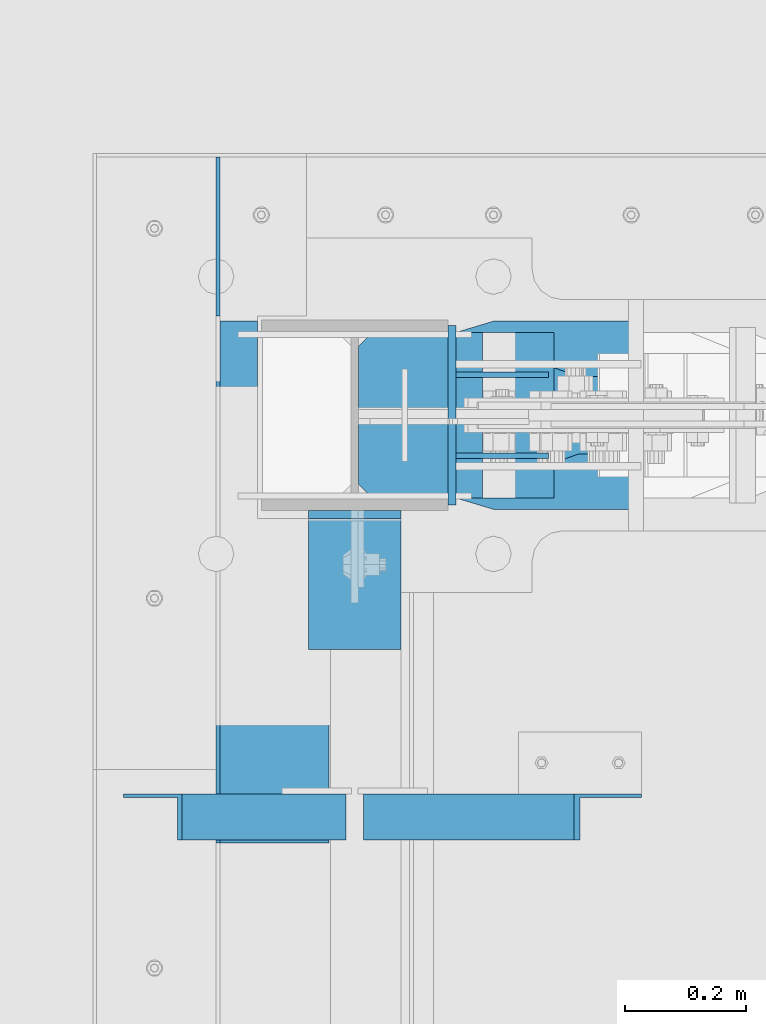
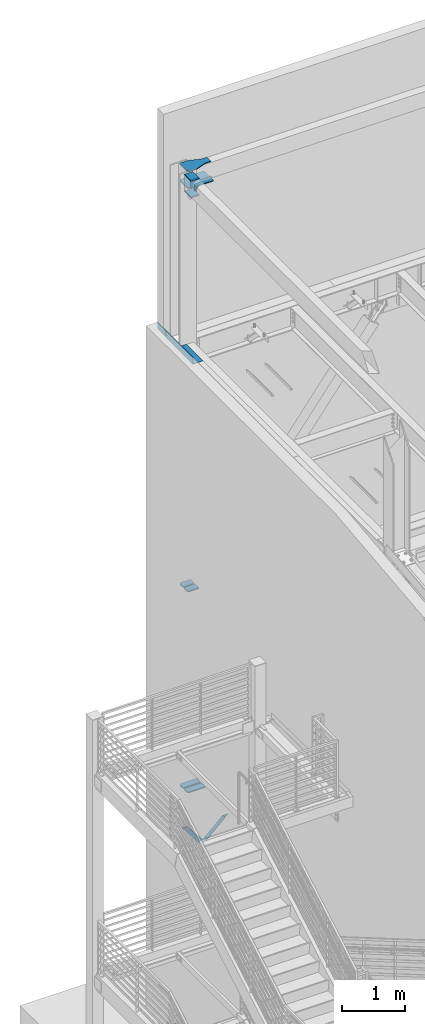
# One storey, part 881 of 1179: 13 beams, 2 members, 8 elements without a shape of their own.
"""IFC2X3 building model written with IfcOpenShell, lengths in millimetres."""

from ifc_helpers import new_model, si_unit, frame, origin_with_axes, place, context, subcontext, project, spatial, faceted_brep, material, type_object, element, aggregate, save


model = new_model("IFC2X3")

# Units and contexts
model_context = context("Model", 3, precision=1e-05, world=origin_with_axes())
body_context = subcontext(model_context, "Body", "Model", "MODEL_VIEW")
ifc_project = project(units=[si_unit("LENGTHUNIT", "METRE", prefix="MILLI"), si_unit("AREAUNIT", "SQUARE_METRE"), si_unit("VOLUMEUNIT", "CUBIC_METRE"), si_unit("MASSUNIT", "GRAM", prefix="KILO"), si_unit("TIMEUNIT", "SECOND"), si_unit("PLANEANGLEUNIT", "RADIAN"), si_unit("SOLIDANGLEUNIT", "STERADIAN"), si_unit("THERMODYNAMICTEMPERATUREUNIT", "DEGREE_CELSIUS"), si_unit("LUMINOUSINTENSITYUNIT", "LUMEN")], contexts=[model_context])

# Site, building, storey
site_placement = place(None, origin_with_axes())
site = spatial("IfcSite", under=ifc_project, at=site_placement, CompositionType="ELEMENT")
building_placement = place(site_placement, origin_with_axes())
building = spatial("IfcBuilding", under=site, at=building_placement, Name="Undefined", CompositionType="ELEMENT")
storey_placement = place(building_placement, origin_with_axes())
storey = spatial("IfcBuildingStorey", under=building, at=storey_placement, Name="Undefined", CompositionType="ELEMENT", Elevation=0.0)

# Assembly, member
assembly_1_placement = place(storey_placement, origin_with_axes())
assembly_1 = element("IfcElementAssembly", 1, at=assembly_1_placement, inside=storey, Name="ANGLE", AssemblyPlace="NOTDEFINED", PredefinedType="RIGID_FRAME")
ifc_material_1 = material(Name="STEEL/A36")
member_type = type_object("IfcMemberType", Name="L3X3X1/4", PredefinedType="NOTDEFINED")
member_1_placement = place(assembly_1_placement, frame((472.414639168561, 40536.8125, 3736.19330123132), z_axis=(0.0, -1.0, 0.0), x_axis=(0.729484494811633, 0.0, 0.683997347823379)))
member_1 = element("IfcMember", 2, at=member_1_placement, type_object=member_type, material=ifc_material_1, Name="ANGLE", ObjectType="L3X3X1/4", context=body_context, shape_type="Brep", body=[
    faceted_brep([(0.0, 38.0999999999985, -38.0999999999999), (0.0, 38.0999999999985, 38.0999999999999), (475.752341075195, 38.0999999999181, 38.1000000000004), (475.752341075195, 38.0999999999181, -38.1000000000004), (0.0, 31.75, 38.1000000000004), (482.524628360803, 31.7499999999177, 38.1000000000004), (0.0, 31.75, -31.75), (482.524628360803, 31.7499999999177, -31.75), (0.0, -38.0999999999985, -31.75), (557.019788502486, -38.1000000000854, -31.75), (0.0, -38.0999999999985, -38.0999999999999), (557.019788502486, -38.1000000000854, -38.1000000000004)], [[[0, 1, 2, 3]], [[1, 4, 5, 2]], [[4, 6, 7, 5]], [[6, 8, 9, 7]], [[8, 10, 11, 9]], [[10, 0, 3, 11]], [[5, 7, 9, 11, 3, 2]], [[10, 8, 6, 4, 1, 0]]]),
])
aggregate(assembly_1, [member_1])

assembly_2_placement = place(storey_placement, origin_with_axes())
assembly_2 = element("IfcElementAssembly", 3, at=assembly_2_placement, inside=storey, Name="ANGLE", AssemblyPlace="NOTDEFINED", PredefinedType="RIGID_FRAME")
member_2_placement = place(assembly_2_placement, frame((80.8196258456446, 40536.8125, 4125.56128839178), z_axis=(0.0, -1.0, 0.0), x_axis=(0.614083067285056, 0.0, -0.789241399366364)))
member_2 = element("IfcMember", 4, at=member_2_placement, type_object=member_type, material=ifc_material_1, Name="ANGLE", ObjectType="L3X3X1/4", context=body_context, shape_type="Brep", body=[
    faceted_brep([(59.3707492954454, 38.0999999999781, -38.1000000000004), (59.3707492954454, 38.0999999999781, 38.1000000000004), (499.083854779058, 38.0999999998585, 38.1000000000004), (499.083854779058, 38.0999999998585, -38.1000000000004), (54.4300207928691, 31.7499999999804, 38.1000000000004), (499.083854779056, 31.7499999998595, 38.1000000000004), (54.4300207928691, 31.7499999999804, -31.75), (499.083854779056, 31.7499999998595, -31.75), (0.0820072645328764, -38.0999999999945, -31.75), (499.083854779043, -38.10000000013, -31.75), (0.0820072645328764, -38.0999999999945, -38.1000000000004), (499.083854779043, -38.10000000013, -38.1000000000004)], [[[0, 1, 2, 3]], [[1, 4, 5, 2]], [[4, 6, 7, 5]], [[6, 8, 9, 7]], [[8, 10, 11, 9]], [[10, 0, 3, 11]], [[5, 7, 9, 11, 3, 2]], [[10, 8, 6, 4, 1, 0]]]),
])
aggregate(assembly_2, [member_2])

# Assembly, beam
assembly_3_placement = place(storey_placement, origin_with_axes())
assembly_3 = element("IfcElementAssembly", 5, at=assembly_3_placement, inside=storey, Name="BEAM", AssemblyPlace="NOTDEFINED", PredefinedType="RIGID_FRAME")
beam_type_1 = type_object("IfcBeamType", PredefinedType="NOTDEFINED")
beam_1_placement = place(assembly_3_placement, frame((388.936999993642, 40924.1973191471, 13122.275), z_axis=(0.0, -1.0, 0.0), x_axis=(-1.0, 0.0, 0.0)))
beam_1 = element("IfcBeam", 6, at=beam_1_placement, type_object=beam_type_1, material=ifc_material_1, Name="BENT_PLATE", context=body_context, shape_type="Brep", body=[
    faceted_brep([(117.474499993628, -3.17499999999927, -104.740180852918), (117.474499993628, 3.17499999999927, -104.740180852918), (117.474482460475, 3.17499999999927, -430.212500000001), (117.474482460475, -3.17499999999927, -430.212500000001), (0.0, -3.17499999999927, -104.740180852918), (0.0, 3.17499999999927, -104.740180852918), (185.737000000001, 3.17499999999927, 430.212500000001), (0.0, 3.17499999999927, 430.212500000001), (0.0, -3.17499999999927, 430.212500000001), (179.387000000001, -3.17499999999927, 430.212500000001), (179.387000000001, -130.175000000001, 430.212500000001), (185.737000000001, -130.175000000001, 430.212500000001), (185.737000000001, 3.17499999999927, -430.212500000001), (185.737000000001, -130.175000000001, -430.212500000001), (179.387000000001, -130.175000000001, -430.212500000001), (179.387000000001, -3.17499999999927, -430.212500000001)], [[[0, 1, 2, 3]], [[4, 5, 1, 0]], [[6, 7, 8, 9, 10, 11]], [[12, 6, 11, 13]], [[10, 14, 13, 11]], [[9, 15, 14, 10]], [[12, 13, 14, 15, 3, 2]], [[7, 6, 12, 2, 1, 5]], [[8, 7, 5, 4]], [[15, 9, 8, 4, 0, 3]]]),
])
aggregate(assembly_3, [beam_1])

# Assembly, beams
assembly_4_placement = place(storey_placement, origin_with_axes())
assembly_4 = element("IfcElementAssembly", 7, at=assembly_4_placement, inside=storey, Name="COLUMN", AssemblyPlace="NOTDEFINED", PredefinedType="RIGID_FRAME")
beam_type_2 = type_object("IfcBeamType", PredefinedType="NOTDEFINED")
beam_2_placement = place(assembly_4_placement, frame((592.13750000001, 41051.1625, 16030.575), z_axis=(0.0, 0.0, 1.0), x_axis=(0.0, 1.0, 0.0)))
beam_2 = element("IfcBeam", 8, at=beam_2_placement, type_object=beam_type_2, material=ifc_material_1, Name="PLATE", context=body_context, shape_type="Brep", body=[
    faceted_brep([(-7.27595761418343e-12, 6.35000000000036, -76.1999999999971), (0.0, 6.35000000000036, 76.2000000000044), (295.274999999994, 6.34999999999854, 76.2000000000007), (295.274999999994, 6.34999999999854, -76.2000000000007), (0.0, -6.35000000000036, 76.2000000000044), (295.274999999994, -6.34999999999854, 76.2000000000007), (7.27595761418343e-12, -6.35000000000036, -76.1999999999971), (295.274999999994, -6.34999999999854, -76.2000000000007)], [[[0, 1, 2, 3]], [[1, 4, 5, 2]], [[4, 6, 7, 5]], [[6, 0, 3, 7]], [[5, 7, 3, 2]], [[6, 4, 1, 0]]]),
])
beam_3_placement = place(assembly_4_placement, frame((431.8, 40813.0375061035, 16116.3), z_axis=(1.0, 0.0, 0.0), x_axis=(0.0, 1.0, 0.0)))
beam_3 = element("IfcBeam", 9, at=beam_3_placement, type_object=beam_type_2, material=ifc_material_1, Name="PLATE", context=body_context, shape_type="Brep", body=[
    faceted_brep([(215.900000000001, 6.35000000000036, 76.2000000000007), (228.599999999999, -6.35000000000036, 76.2000000000007), (228.599999999999, -6.35000000000036, -76.2000000000007), (215.900000000001, 6.35000000000036, -76.2000000000007), (-7.27595761418343e-12, 6.35000000000036, -76.1999999999971), (0.0, 6.35000000000036, 76.2000000000044), (0.0, -6.35000000000036, 76.2000000000044), (7.27595761418343e-12, -6.35000000000036, -76.1999999999971)], [[[0, 1, 2, 3]], [[4, 5, 0, 3]], [[5, 6, 1, 0]], [[6, 7, 2, 1]], [[7, 4, 3, 2]], [[7, 6, 5, 4]]]),
])
beam_4_placement = place(assembly_4_placement, frame((431.8, 40813.0375059853, 16435.3875), z_axis=(1.0, 0.0, 0.0), x_axis=(0.0, 1.0, 0.0)))
beam_4 = element("IfcBeam", 10, at=beam_4_placement, type_object=beam_type_2, material=ifc_material_1, Name="PLATE", context=body_context, shape_type="Brep", body=[
    faceted_brep([(215.900000000001, 6.35000000000036, 76.2000000000007), (228.599999999999, -6.35000000000036, 76.2000000000007), (228.599999999999, -6.35000000000036, -76.2000000000007), (215.900000000001, 6.35000000000036, -76.2000000000007), (-7.27595761418343e-12, 6.35000000000036, -76.1999999999971), (0.0, 6.35000000000036, 76.2000000000044), (0.0, -6.35000000000036, 76.2000000000044), (7.27595761418343e-12, -6.35000000000036, -76.1999999999971)], [[[0, 1, 2, 3]], [[4, 5, 0, 3]], [[5, 6, 1, 0]], [[6, 7, 2, 1]], [[7, 4, 3, 2]], [[7, 6, 5, 4]]]),
])

# Assembly, beam
assembly_5_placement = place(storey_placement, origin_with_axes())
assembly_5 = element("IfcElementAssembly", 11, at=assembly_5_placement, inside=storey, Name="PLATE", AssemblyPlace="NOTDEFINED", PredefinedType="RIGID_FRAME")
ifc_material_2 = material(Name="STEEL/A572-GR.50")
beam_type_3 = type_object("IfcBeamType", PredefinedType="NOTDEFINED")
beam_5_placement = place(assembly_5_placement, frame((438.15, 41124.981, 4351.42154734331), z_axis=(0.0, 1.0, 0.0), x_axis=(1.0, 0.0, 0.0)))
beam_5 = element("IfcBeam", 12, at=beam_5_placement, type_object=beam_type_3, material=ifc_material_2, Name="PLATE", context=body_context, shape_type="Brep", body=[
    faceted_brep([(0.0, 9.52499999999964, -40.4814999999999), (22.2249999999985, 9.52499999999964, -62.7065000000002), (22.2249999999985, -9.52499999999964, -62.7065000000002), (0.0, -9.52499999999964, -40.4814999999999), (0.0, 9.52499999999964, 62.7065000000002), (322.236471870045, 9.52499999999964, 62.7065000000002), (322.236471870045, 9.52499999999964, -62.7065000000002), (0.0, -9.52499999999964, 62.7065000000002), (322.236471870045, -9.52499999999964, 62.7065000000002), (322.236471870045, -9.52499999999964, -62.7065000000002)], [[[0, 1, 2, 3]], [[4, 5, 6, 1, 0]], [[4, 7, 8, 5]], [[9, 8, 7, 3, 2]], [[6, 9, 2, 1]], [[8, 9, 6, 5]], [[7, 4, 0, 3]]]),
])
aggregate(assembly_5, [beam_5])

assembly_6_placement = place(storey_placement, origin_with_axes())
assembly_6 = element("IfcElementAssembly", 13, at=assembly_6_placement, inside=storey, Name="PLATE", AssemblyPlace="NOTDEFINED", PredefinedType="RIGID_FRAME")
beam_6_placement = place(assembly_6_placement, frame((438.15, 41272.619, 4351.42154734331), z_axis=(0.0, -1.0, 0.0), x_axis=(1.0, 0.0, 0.0)))
beam_6 = element("IfcBeam", 14, at=beam_6_placement, type_object=beam_type_3, material=ifc_material_2, Name="PLATE", context=body_context, shape_type="Brep", body=[
    faceted_brep([(0.0, 9.52499999999964, -40.4814999999999), (22.2249999999985, 9.52499999999964, -62.7065000000002), (22.2249999999985, -9.52499999999964, -62.7065000000002), (0.0, -9.52499999999964, -40.4814999999999), (0.0, 9.52499999999964, 62.7065000000002), (322.236471870045, 9.52499999999964, 62.7065000000002), (322.236471870045, 9.52499999999964, -62.7065000000002), (0.0, -9.52499999999964, 62.7065000000002), (322.236471870045, -9.52499999999964, 62.7065000000002), (322.236471870045, -9.52499999999964, -62.7065000000002)], [[[0, 1, 2, 3]], [[4, 5, 6, 1, 0]], [[4, 7, 8, 5]], [[9, 8, 7, 3, 2]], [[6, 9, 2, 1]], [[8, 9, 6, 5]], [[7, 4, 0, 3]]]),
])
aggregate(assembly_6, [beam_6])

# Beam
beam_type_4 = type_object("IfcBeamType", PredefinedType="NOTDEFINED")
beam_7_placement = place(assembly_4_placement, frame((438.149999999996, 41125.775, 8263.92332782742), z_axis=(0.0, -1.0, 0.0), x_axis=(1.0, 0.0, 0.0)))
beam_7 = element("IfcBeam", 15, at=beam_7_placement, type_object=beam_type_4, material=ifc_material_2, Name="PLATE", context=body_context, shape_type="Brep", body=[
    faceted_brep([(1.81898940354586e-11, -9.52499999999782, 41.2750000000015), (22.2250000000204, -9.525000000006, 63.5), (22.2249999999913, 9.52499999999327, 63.5), (-7.27595761418343e-12, 9.52500000000146, 41.2750000000015), (204.151296232532, 9.52499999999964, 63.5), (204.151296232532, 9.52499999999964, -63.5), (0.0, 9.52500000000146, -63.5), (204.151296232532, -9.52499999999964, 63.5), (0.0, -9.52500000000146, -63.5), (204.151296232532, -9.52499999999964, -63.5)], [[[0, 1, 2, 3]], [[4, 5, 6, 3, 2]], [[7, 4, 2, 1]], [[8, 9, 7, 1, 0]], [[8, 6, 5, 9]], [[7, 9, 5, 4]], [[6, 8, 0, 3]]]),
])

beam_8_placement = place(assembly_4_placement, frame((438.149999999996, 41271.825, 8263.92332782742), z_axis=(0.0, 1.0, 0.0), x_axis=(1.0, 0.0, 0.0)))
beam_8 = element("IfcBeam", 16, at=beam_8_placement, type_object=beam_type_4, material=ifc_material_2, Name="PLATE", context=body_context, shape_type="Brep", body=[
    faceted_brep([(1.81898940354586e-11, -9.52499999999782, 41.2750000000015), (22.2250000000204, -9.525000000006, 63.5), (22.2249999999913, 9.52499999999327, 63.5), (-7.27595761418343e-12, 9.52500000000146, 41.2750000000015), (204.151296232532, 9.52499999999964, 63.5), (204.151296232532, 9.52499999999964, -63.5), (0.0, 9.52500000000146, -63.5), (204.151296232532, -9.52499999999964, 63.5), (0.0, -9.52500000000146, -63.5), (204.151296232532, -9.52499999999964, -63.5)], [[[0, 1, 2, 3]], [[4, 5, 6, 3, 2]], [[7, 4, 2, 1]], [[8, 9, 7, 1, 0]], [[8, 6, 5, 9]], [[7, 9, 5, 4]], [[6, 8, 0, 3]]]),
])

# Assembly, beam
assembly_7_placement = place(storey_placement, origin_with_axes())
assembly_7 = element("IfcElementAssembly", 17, at=assembly_7_placement, inside=storey, Name="BEAM", AssemblyPlace="NOTDEFINED", PredefinedType="RIGID_FRAME")
beam_type_5 = type_object("IfcBeamType", PredefinedType="NOTDEFINED")
beam_9_placement = place(assembly_7_placement, frame((206.374500000004, 41362.3125, 13188.9500061035), z_axis=(0.0, 0.0, 1.0), x_axis=(0.0, 1.0, 0.0)))
beam_9 = element("IfcBeam", 18, at=beam_9_placement, type_object=beam_type_5, material=ifc_material_1, Name="PLATE", context=body_context, shape_type="Brep", body=[
    faceted_brep([(261.937500000007, -3.17500000000001, -44.4500000000007), (242.887500000004, -3.17500000000001, -63.5), (242.887500000004, 3.17500000000001, -63.5), (261.937500000007, 3.17500000000001, -44.4500000000007), (0.0, 3.17499999999927, -63.5), (0.0, 3.17499999999927, 63.5), (261.937500000007, 3.17500000000001, 63.5), (0.0, -3.17499999999927, 63.5), (261.937500000007, -3.17500000000001, 63.5), (0.0, -3.17499999999927, -63.5)], [[[0, 1, 2, 3]], [[4, 5, 6, 3, 2]], [[5, 7, 8, 6]], [[8, 7, 9, 1, 0]], [[9, 4, 2, 1]], [[6, 8, 0, 3]], [[9, 7, 5, 4]]]),
])
aggregate(assembly_7, [beam_9])

# Beam
beam_type_6 = type_object("IfcBeamType", PredefinedType="NOTDEFINED")
beam_10_placement = place(assembly_4_placement, frame((750.88750000001, 41132.125, 16030.575), z_axis=(0.0, 0.0, 1.0), x_axis=(-1.0, 0.0, 0.0)))
beam_10 = element("IfcBeam", 19, at=beam_10_placement, type_object=beam_type_6, material=ifc_material_1, Name="PLATE", context=body_context, shape_type="Brep", body=[
    faceted_brep([(152.4, -4.76249999999709, 76.2), (152.4, -4.76249999999709, -76.2), (152.4, 4.76249999999709, -76.2), (152.4, 4.76249999999709, 76.2), (0.0, 4.76249999999982, 76.1999999999971), (0.0, -4.76249999999982, 76.1999999999971)], [[[0, 1, 2, 3]], [[3, 2, 4]], [[4, 5, 0, 3]], [[0, 5, 1]], [[4, 2, 1, 5]]]),
])

beam_11_placement = place(assembly_4_placement, frame((750.88750000001, 41265.475, 16030.575), z_axis=(0.0, 0.0, 1.0), x_axis=(-1.0, 0.0, 0.0)))
beam_11 = element("IfcBeam", 20, at=beam_11_placement, type_object=beam_type_6, material=ifc_material_1, Name="PLATE", context=body_context, shape_type="Brep", body=[
    faceted_brep([(152.4, -4.76249999999709, 76.2), (152.4, -4.76249999999709, -76.2), (152.4, 4.76249999999709, -76.2), (152.4, 4.76249999999709, 76.2), (0.0, 4.76249999999982, 76.1999999999971), (0.0, -4.76249999999982, 76.1999999999971)], [[[0, 1, 2, 3]], [[3, 2, 4]], [[4, 5, 0, 3]], [[0, 5, 1]], [[4, 2, 1, 5]]]),
])

beam_type_7 = type_object("IfcBeamType", PredefinedType="NOTDEFINED")
beam_12_placement = place(assembly_4_placement, frame((903.287500000004, 41198.8, 16114.7125), z_axis=(0.0, 1.0, 0.0), x_axis=(-1.0, 0.0, 0.0)))
beam_12 = element("IfcBeam", 21, at=beam_12_placement, type_object=beam_type_7, material=ifc_material_1, Name="PLATE", context=body_context, shape_type="Brep", body=[
    faceted_brep([(465.137499999997, -7.9375, -114.300000762945), (442.912499999999, -7.9375, -136.525000762944), (442.912500000006, 7.9375, -136.525000762944), (465.137500000004, 7.9375, -114.300000762945), (465.137500000004, 7.9375, 114.300000762938), (442.912500000006, 7.9375, 136.525000762937), (442.912499999999, -7.9375, 136.525000762937), (465.137499999997, -7.9375, 114.300000762938), (241.300006103491, -7.9375, -155.575000000001), (241.300006103491, 7.9375, -155.575000000001), (304.799990844724, 7.9375, -136.525000762944), (304.799990844724, -7.9375, -136.525000762944), (0.0, -7.9375, -155.575000000001), (0.0, -7.9375, 155.575000000001), (0.0, 7.9375, 155.575000000001), (0.0, 7.9375, -155.575000000001), (241.300006103513, -7.9375, 155.575000000001), (241.300006103513, 7.9375, 155.575000000001), (304.799990844724, -7.9375, 136.525000762937), (304.799990844724, 7.9375, 136.525000762937)], [[[0, 1, 2, 3]], [[4, 5, 6, 7]], [[8, 9, 10, 11]], [[11, 10, 2, 1]], [[12, 13, 14, 15]], [[14, 13, 16, 17]], [[18, 19, 17, 16]], [[19, 18, 6, 5]], [[4, 7, 0, 3]], [[10, 9, 15, 14, 17, 19, 5, 4, 3, 2]], [[12, 15, 9, 8]], [[7, 6, 18, 16, 13, 12, 8, 11, 1, 0]]]),
])

aggregate(assembly_4, [beam_10, beam_11, beam_12, beam_2, beam_3, beam_4, beam_7, beam_8])

# Assembly, beam
assembly_8_placement = place(storey_placement, origin_with_axes())
assembly_8 = element("IfcElementAssembly", 22, at=assembly_8_placement, inside=storey, Name="PLATE", AssemblyPlace="NOTDEFINED", PredefinedType="RIGID_FRAME")
beam_type_8 = type_object("IfcBeamType", PredefinedType="NOTDEFINED")
beam_13_placement = place(assembly_8_placement, frame((903.287500000004, 41198.8, 16435.3875), z_axis=(0.0, 1.0, 0.0), x_axis=(-1.0, 0.0, 0.0)))
beam_13 = element("IfcBeam", 23, at=beam_13_placement, type_object=beam_type_8, material=ifc_material_1, Name="PLATE", context=body_context, shape_type="Brep", body=[
    faceted_brep([(465.137499999997, -7.9375, -114.300000762945), (442.912499999999, -7.9375, -136.525000762944), (442.912500000006, 7.9375, -136.525000762944), (465.137500000004, 7.9375, -114.300000762945), (465.137500000004, 7.9375, 114.300000762938), (442.912500000006, 7.9375, 136.525000762937), (442.912499999999, -7.9375, 136.525000762937), (465.137499999997, -7.9375, 114.300000762938), (97.1744871646697, -7.9375, 63.4999984741225), (97.1744871646697, 7.9375, 63.4999984741225), (0.0, 7.9375, 63.5), (0.0, -7.9375, 63.5), (99.3625358760146, -7.9375, 63.5944172169256), (99.3625358760146, 7.9375, 63.5944172169256), (101.534317436837, -7.9375, 63.8769714847585), (101.534317436837, 7.9375, 63.8769714847585), (103.673685635511, -7.9375, 64.3455606147181), (103.673685635511, 7.9375, 64.3455606147181), (105.764735239063, -7.9375, 64.9967008589738), (105.764735239063, 7.9375, 64.9967008589738), (304.799990844724, -7.9375, 136.525000762937), (304.799990844724, 7.9375, 136.525000762937), (0.0, -7.9375, -63.5), (0.0, 7.9375, -63.5), (97.1744871646697, 7.9375, -63.5), (97.1744871646697, -7.9375, -63.5), (99.3625358760146, 7.9375, -63.5944187428031), (99.3625358760146, -7.9375, -63.5944187428031), (101.534317436837, 7.9375, -63.876973010636), (101.534317436837, -7.9375, -63.876973010636), (103.673685635511, 7.9375, -64.3455621405956), (103.673685635511, -7.9375, -64.3455621405956), (105.764735239063, 7.9375, -64.9967023848512), (105.764735239063, -7.9375, -64.9967023848512), (304.799990844724, -7.9375, -136.525000762944), (304.799990844724, 7.9375, -136.525000762944)], [[[0, 1, 2, 3]], [[4, 5, 6, 7]], [[8, 9, 10, 11]], [[12, 13, 9, 8]], [[14, 15, 13, 12]], [[16, 17, 15, 14]], [[18, 19, 17, 16]], [[20, 21, 19, 18]], [[22, 23, 24, 25]], [[25, 24, 26, 27]], [[27, 26, 28, 29]], [[29, 28, 30, 31]], [[31, 30, 32, 33]], [[34, 33, 32, 35]], [[34, 35, 2, 1]], [[4, 7, 0, 3]], [[7, 6, 20, 18, 16, 14, 12, 8, 11, 22, 25, 27, 29, 31, 33, 34, 1, 0]], [[22, 11, 10, 23]], [[35, 32, 30, 28, 26, 24, 23, 10, 9, 13, 15, 17, 19, 21, 5, 4, 3, 2]], [[21, 20, 6, 5]]]),
])
aggregate(assembly_8, [beam_13])

save(model, "model.ifc")
